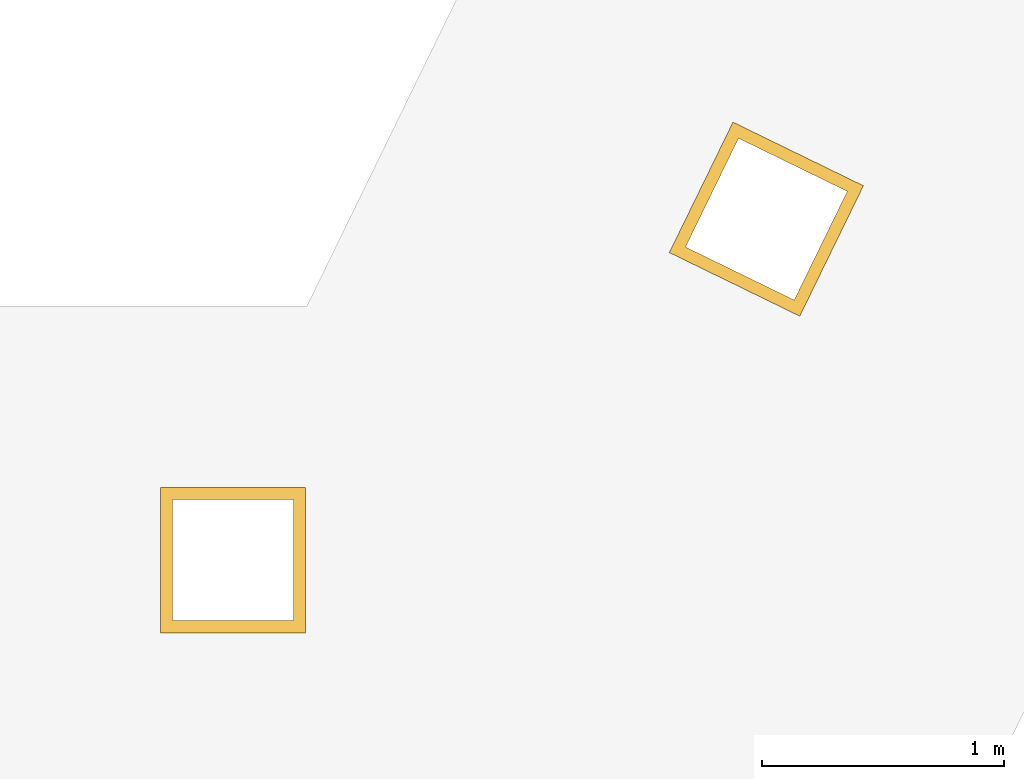
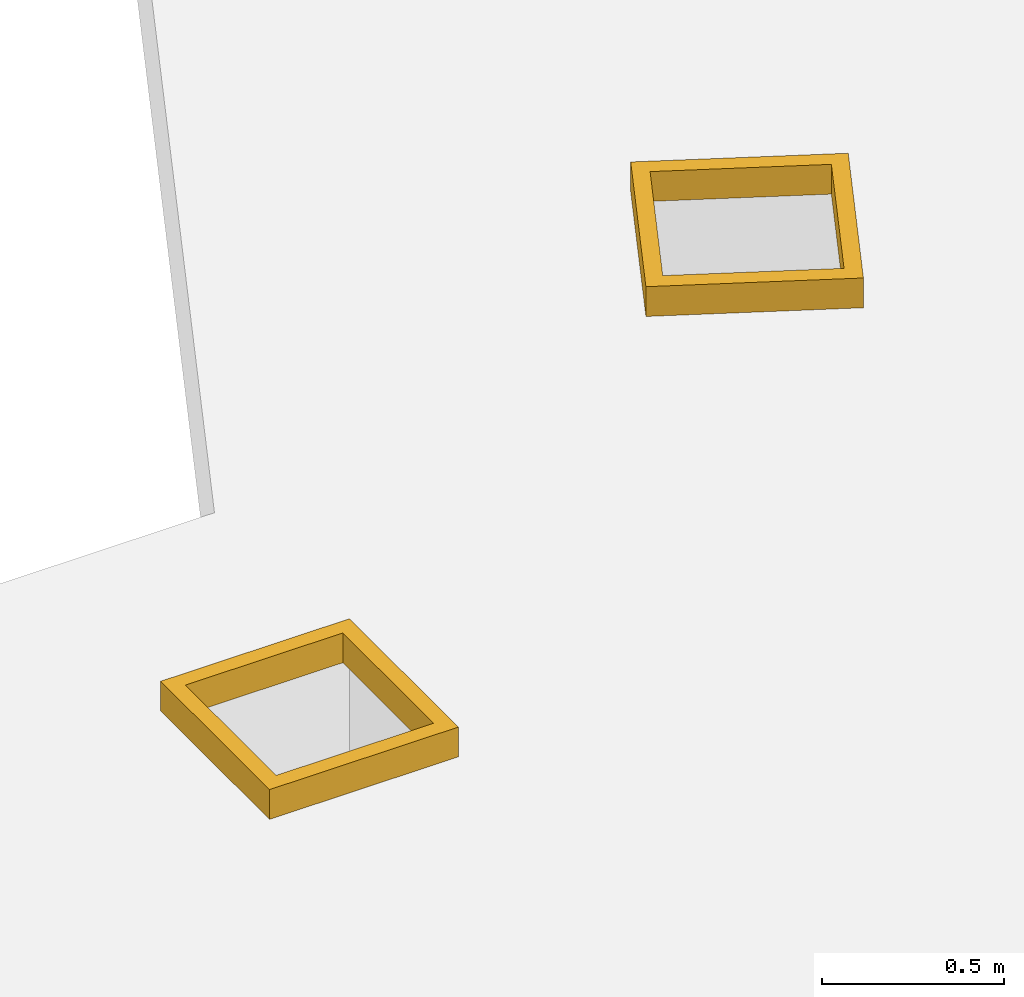
# One storey, part 2 of 2: 2 windows.
"""IFC4 building model written with IfcOpenShell, lengths in metres."""

import ifcopenshell
import ifcopenshell.guid

model = None  # the IFC model being written
_history = None  # IfcOwnerHistory: only IFC2X3 demands one
_inside = {}  # id of a spatial element -> (the spatial element, [elements in it])
_under = {}  # id of a project, library or spatial element -> (it, [spatial elements below it])
_declared = {}  # id of a project -> (the project, [libraries it declares])
_typed = {}  # id of a type object -> (the type object, [elements of that type])
_made_of = {}  # id of a material, layer set ... -> (it, [elements and type objects made of it])


def new_model(schema):
    """Start an empty IFC model of exactly this schema.

    Asked for "IFC4X3", IfcOpenShell would pick the latest addendum, in which some entities
    have other attributes; the version numbers below select the first issue.
    IFC2X3 requires an IfcOwnerHistory on every rooted entity: one is made here for all.
    """
    global model, _history
    if schema == "IFC4X3":
        model = ifcopenshell.file(schema_version=(4, 3, 0, 0))
    else:
        model = ifcopenshell.file(schema=schema)
    _inside.clear()
    _under.clear()
    _declared.clear()
    _typed.clear()
    _made_of.clear()
    _history = None
    if model.schema == "IFC2X3":
        org = make("IfcOrganization", Name="unknown")
        user = make(
            "IfcPersonAndOrganization",
            ThePerson=make("IfcPerson", FamilyName="unknown"),
            TheOrganization=org,
        )
        app = make(
            "IfcApplication",
            ApplicationDeveloper=org,
            Version="unknown",
            ApplicationFullName="unknown",
            ApplicationIdentifier="unknown",
        )
        _history = make(
            "IfcOwnerHistory",
            OwningUser=user,
            OwningApplication=app,
            ChangeAction="ADDED",
            CreationDate=0,
        )
    return model


def make(cls, **values):
    """One entity of the class cls with the attributes given. An attribute that is None is left unset."""
    return model.create_entity(
        cls, **{name: value for name, value in values.items() if value is not None}
    )


def entity(cls, *values):
    """Any entity or typed value of the class cls, its attributes in the order of the schema. None: left unset."""
    e = model.create_entity(cls)
    for i, value in enumerate(values):
        if value is not None:
            e[i] = value
    return e


def rooted(cls, **values):
    """An entity with a GlobalId (a new one), such as an element, a storey or a relation."""
    return make(cls, GlobalId=ifcopenshell.guid.new(), OwnerHistory=_history, **values)


def si_unit(unit_type, name, prefix=None):
    """IfcSIUnit, for example si_unit("LENGTHUNIT", "METRE", prefix="MILLI")."""
    return make("IfcSIUnit", UnitType=unit_type, Prefix=prefix, Name=name)


def converted_unit(unit_type, name, factor, base, dimensions=None, offset=None):
    """IfcConversionBasedUnit, such as the inch: factor (a typed value) times the base unit."""
    return make(
        "IfcConversionBasedUnit"
        if offset is None
        else "IfcConversionBasedUnitWithOffset",
        ConversionOffset=offset,
        Dimensions=None
        if dimensions is None
        else entity("IfcDimensionalExponents", *dimensions),
        UnitType=unit_type,
        Name=name,
        ConversionFactor=make(
            "IfcMeasureWithUnit", ValueComponent=factor, UnitComponent=base
        ),
    )


def derived_unit(unit_type, elements):
    """IfcDerivedUnit: a product of units, each with its exponent."""
    return make(
        "IfcDerivedUnit",
        Elements=[
            make("IfcDerivedUnitElement", Unit=unit, Exponent=power)
            for unit, power in elements
        ],
        UnitType=unit_type,
    )


def assignment(units):
    """IfcUnitAssignment: the units of a project."""
    return None if units is None else make("IfcUnitAssignment", Units=units)


def point(xyz):
    """IfcCartesianPoint."""
    return None if xyz is None else make("IfcCartesianPoint", Coordinates=xyz)


def direction(xyz):
    """IfcDirection."""
    return None if xyz is None else make("IfcDirection", DirectionRatios=xyz)


def frame(location, z_axis=None, x_axis=None):
    """IfcAxis2Placement3D, a coordinate frame: its origin and axes. An axis left out is left unset."""
    return make(
        "IfcAxis2Placement3D",
        Location=point(location),
        Axis=direction(z_axis),
        RefDirection=direction(x_axis),
    )


def origin():
    """The frame at (0, 0, 0) with its axes left unset."""
    return frame((0.0, 0.0, 0.0))


def place(relative_to, where):
    """IfcLocalPlacement: puts the frame where relative to a parent placement (None: the world)."""
    return make(
        "IfcLocalPlacement", PlacementRelTo=relative_to, RelativePlacement=where
    )


def context(
    kind, dimensions, precision=None, world=None, true_north=None, identifier=None
):
    """IfcGeometricRepresentationContext, for example the 3D "Model" context."""
    return make(
        "IfcGeometricRepresentationContext",
        ContextIdentifier=identifier,
        ContextType=kind,
        CoordinateSpaceDimension=dimensions,
        Precision=precision,
        WorldCoordinateSystem=world,
        TrueNorth=true_north,
    )


def subcontext(parent, identifier, kind, view, scale=None):
    """IfcGeometricRepresentationSubContext, for example "Body" below "Model"."""
    return make(
        "IfcGeometricRepresentationSubContext",
        ContextIdentifier=identifier,
        ContextType=kind,
        ParentContext=parent,
        TargetScale=scale,
        TargetView=view,
    )


def project(units=None, contexts=None):
    """IfcProject with its units and contexts."""
    return rooted(
        "IfcProject",
        Name="project",
        RepresentationContexts=contexts,
        UnitsInContext=assignment(units),
    )


def spatial(cls, under=None, at=None, **own):
    """A site, building, storey or space (cls), placed at a placement, below another one or the project."""
    s = rooted(cls, ObjectPlacement=at, **own)
    if under is not None:
        _under.setdefault(under.id(), (under, []))[1].append(s)
    return s


def point_list(points):
    """IfcCartesianPointList2D or 3D."""
    cls = (
        "IfcCartesianPointList2D" if len(points[0]) == 2 else "IfcCartesianPointList3D"
    )
    return make(cls, CoordList=points)


def polygons(points, faces, closed=None, point_numbers=None):
    """IfcPolygonalFaceSet: a face is its outer loop, then its inner loops; points numbered from 1."""
    made = []
    for loops in faces:
        if len(loops) == 1:
            made.append(make("IfcIndexedPolygonalFace", CoordIndex=loops[0]))
        else:
            made.append(
                make(
                    "IfcIndexedPolygonalFaceWithVoids",
                    CoordIndex=loops[0],
                    InnerCoordIndices=loops[1:],
                )
            )
    return make(
        "IfcPolygonalFaceSet",
        Coordinates=point_list(points),
        Closed=closed,
        Faces=made,
        PnIndex=point_numbers,
    )


def shape(context_of_items, identifier, shape_type, items):
    """IfcShapeRepresentation: the items that make up one representation, for example the "Body"."""
    return make(
        "IfcShapeRepresentation",
        ContextOfItems=context_of_items,
        RepresentationIdentifier=identifier,
        RepresentationType=shape_type,
        Items=items,
    )


def source(mapping_origin, context_of_items, identifier, shape_type, items):
    """IfcRepresentationMap: a shape defined once, which mapped items show again and again."""
    return make(
        "IfcRepresentationMap",
        MappingOrigin=mapping_origin,
        MappedRepresentation=shape(context_of_items, identifier, shape_type, items),
    )


def transform(
    local_origin,
    x_axis=None,
    y_axis=None,
    z_axis=None,
    scale=None,
    scale2=None,
    scale3=None,
    uniform=True,
):
    """IfcCartesianTransformationOperator3D, or its non-uniform kind. x_axis, y_axis, z_axis: its Axis1, 2, 3."""
    if uniform:
        return make(
            "IfcCartesianTransformationOperator3D",
            Axis1=direction(x_axis),
            Axis2=direction(y_axis),
            LocalOrigin=point(local_origin),
            Scale=scale,
            Axis3=direction(z_axis),
        )
    return make(
        "IfcCartesianTransformationOperator3DnonUniform",
        Axis1=direction(x_axis),
        Axis2=direction(y_axis),
        LocalOrigin=point(local_origin),
        Scale=scale,
        Axis3=direction(z_axis),
        Scale2=scale2,
        Scale3=scale3,
    )


def mapped(mapping_source, mapping_target):
    """IfcMappedItem: shows the shape of a source again, moved by a transform."""
    return make(
        "IfcMappedItem", MappingSource=mapping_source, MappingTarget=mapping_target
    )


def material(Name=None, Category=None):
    """IfcMaterial."""
    return make("IfcMaterial", Name=Name, Category=Category)


def made_of(thing, what):
    """Note that an element or type object is made of a material, layer set ...; save() writes the relation."""
    if what is not None:
        _made_of.setdefault(what.id(), (what, []))[1].append(thing)
    return thing


def type_object(cls, material=None, **own):
    """A type object (cls), such as IfcWallType, which elements share."""
    return made_of(rooted(cls, **own), material)


def type_shapes(of_type, sources):
    """Give a type object the sources (RepresentationMaps) that its elements show as mapped items."""
    of_type.RepresentationMaps = sources


def element(
    cls,
    number,
    at=None,
    inside=None,
    cuts=None,
    type_object=None,
    material=None,
    context=None,
    identifier="Body",
    shape_type=None,
    held_by="IfcProductDefinitionShape",
    body=None,
    shapes=None,
    **own,
):
    """One element of the class cls, such as IfcWall. Its Tag is "e" and its number.

    at: its placement. inside: the storey or other place that contains it. cuts: it is an
    opening in that element (IfcRelVoidsElement). A single representation is given by context,
    identifier, shape_type and body (its items); several are given by shapes. held_by: the class
    of the entity that holds the representations. save() writes the other relations.
    """
    e = rooted(cls, Tag="e%d" % number, ObjectPlacement=at, **own)
    if body is not None:
        shapes = [shape(context, identifier, shape_type, body)]
    if shapes is not None:
        e.Representation = make(held_by, Representations=shapes)
    if inside is not None:
        _inside.setdefault(inside.id(), (inside, []))[1].append(e)
    if cuts is not None:
        rooted(
            "IfcRelVoidsElement", RelatingBuildingElement=cuts, RelatedOpeningElement=e
        )
    if type_object is not None:
        _typed.setdefault(type_object.id(), (type_object, []))[1].append(e)
    return made_of(e, material)


def aggregate(whole, parts):
    """IfcRelAggregates: a whole, such as a stair, and the parts it consists of."""
    return rooted("IfcRelAggregates", RelatingObject=whole, RelatedObjects=parts)


def save(model, path):
    """Write the relations noted so far, then the file.

    IfcRelAggregates (storeys below a building ...), IfcRelContainedInSpatialStructure (elements
    in a storey), IfcRelDefinesByType, IfcRelAssociatesMaterial and IfcRelDeclares: one each for
    every whole, place, type object, material and project.
    """
    for whole, parts in _under.values():
        aggregate(whole, parts)
    for where, things in _inside.values():
        rooted(
            "IfcRelContainedInSpatialStructure",
            RelatedElements=things,
            RelatingStructure=where,
        )
    for kind, things in _typed.values():
        rooted("IfcRelDefinesByType", RelatedObjects=things, RelatingType=kind)
    for what, things in _made_of.values():
        rooted("IfcRelAssociatesMaterial", RelatedObjects=things, RelatingMaterial=what)
    for by, libraries in _declared.values():
        rooted("IfcRelDeclares", RelatingContext=by, RelatedDefinitions=libraries)
    model.write(path)


model = new_model("IFC4")

# Units and contexts
model_context = context("Model", 3, precision=1e-05, world=origin(), true_north=direction((6.12303176911189e-17, 1.0)))
body_context = subcontext(model_context, "Body", "Model", "MODEL_VIEW")
ifc_project = project(units=[si_unit("LENGTHUNIT", "METRE"), si_unit("AREAUNIT", "SQUARE_METRE"), si_unit("VOLUMEUNIT", "CUBIC_METRE"), converted_unit("PLANEANGLEUNIT", "DEGREE", entity("IfcRatioMeasure", 0.0174532925199433), si_unit("PLANEANGLEUNIT", "RADIAN"), dimensions=[0, 0, 0, 0, 0, 0, 0]), si_unit("MASSUNIT", "GRAM", prefix="KILO"), derived_unit("MASSDENSITYUNIT", [(si_unit("MASSUNIT", "GRAM", prefix="KILO"), 1), (si_unit("LENGTHUNIT", "METRE"), -3)]), si_unit("TIMEUNIT", "SECOND"), si_unit("FREQUENCYUNIT", "HERTZ"), si_unit("THERMODYNAMICTEMPERATUREUNIT", "DEGREE_CELSIUS"), derived_unit("THERMALTRANSMITTANCEUNIT", [(si_unit("MASSUNIT", "GRAM", prefix="KILO"), 1), (si_unit("THERMODYNAMICTEMPERATUREUNIT", "KELVIN"), -1), (si_unit("TIMEUNIT", "SECOND"), -3)]), derived_unit("VOLUMETRICFLOWRATEUNIT", [(si_unit("LENGTHUNIT", "METRE"), 3), (si_unit("TIMEUNIT", "SECOND"), -1)]), si_unit("ELECTRICCURRENTUNIT", "AMPERE"), si_unit("ELECTRICVOLTAGEUNIT", "VOLT"), si_unit("POWERUNIT", "WATT"), si_unit("FORCEUNIT", "NEWTON", prefix="KILO"), si_unit("ILLUMINANCEUNIT", "LUX"), si_unit("LUMINOUSFLUXUNIT", "LUMEN"), si_unit("LUMINOUSINTENSITYUNIT", "CANDELA"), derived_unit("USERDEFINED", [(si_unit("MASSUNIT", "GRAM", prefix="KILO"), -1), (si_unit("LENGTHUNIT", "METRE"), -2), (si_unit("TIMEUNIT", "SECOND"), 3), (si_unit("LUMINOUSFLUXUNIT", "LUMEN"), 1)]), derived_unit("LINEARVELOCITYUNIT", [(si_unit("LENGTHUNIT", "METRE"), 1), (si_unit("TIMEUNIT", "SECOND"), -1)]), si_unit("PRESSUREUNIT", "PASCAL"), derived_unit("USERDEFINED", [(si_unit("LENGTHUNIT", "METRE"), -2), (si_unit("MASSUNIT", "GRAM", prefix="KILO"), 1), (si_unit("TIMEUNIT", "SECOND"), -2)])], contexts=[model_context])

# Site, building, storey
site_placement = place(None, origin())
site = spatial("IfcSite", under=ifc_project, at=site_placement, CompositionType="ELEMENT")
building_placement = place(site_placement, origin())
building = spatial("IfcBuilding", under=site, at=building_placement, Name="Revit Advanced Sample", CompositionType="ELEMENT")
storey_placement = place(building_placement, frame((0.0, 0.0, 3.80000000000133)))
storey = spatial("IfcBuildingStorey", under=building, at=storey_placement, Name="E1", CompositionType="ELEMENT", Elevation=3.80000000000133)

# Windows
ifc_material = material()
window_type = type_object("IfcWindowType", Name="600mm x 600mm", ParameterTakesPrecedence=False, PartitioningType="NOTDEFINED", PredefinedType="WINDOW", material=ifc_material)
shared_shape = source(origin(), body_context, "Body", "Tessellation", [
    polygons([(-0.380000000000003, -0.560000000000002, 4.0576), (-0.330000000000012, -0.510000000000011, 4.0576), (0.170000000000005, -0.510000000000011, 4.0576), (0.219999999999996, -0.560000000000002, 4.0576), (-0.380000000000003, -0.560000000000002, 4.1576), (0.219999999999996, -0.560000000000002, 4.1576), (-0.330000000000012, -0.510000000000011, 4.1576), (0.170000000000005, -0.510000000000011, 4.1576), (0.170000000000005, -0.00999999999999482, 4.0576), (0.219999999999996, 0.039999999999996, 4.0576), (0.219999999999996, 0.039999999999996, 4.1576), (0.170000000000005, -0.00999999999999482, 4.1576), (-0.330000000000012, -0.00999999999999483, 4.0576), (-0.380000000000003, 0.0399999999999959, 4.0576), (-0.380000000000003, 0.0399999999999959, 4.1576), (-0.330000000000012, -0.00999999999999483, 4.1576)], [[[1, 14, 10, 4], [3, 9, 13, 2]], [[5, 1, 4, 6]], [[9, 12, 16, 13]], [[6, 11, 15, 5], [7, 16, 12, 8]], [[2, 7, 8, 3]], [[11, 10, 14, 15]], [[6, 4, 10, 11]], [[13, 16, 7, 2]], [[3, 8, 12, 9]], [[15, 14, 1, 5]]], closed=True),
])
type_shapes(window_type, [shared_shape])
window_1_placement = place(storey_placement, frame((0.781761701821966, -3.43603282121672, -3.6576)))
element("IfcWindow", 1, at=window_1_placement, inside=storey, type_object=window_type, material=ifc_material, OverallHeight=0.778250561573641, OverallWidth=0.997150419015361, PartitioningType="NOTDEFINED", PredefinedType="WINDOW", context=body_context, shape_type="MappedRepresentation", body=[
    mapped(shared_shape, transform((0.0, 0.0, 0.0), scale=1.0)),
])
window_2_placement = place(storey_placement, frame((3.09185339799384, -2.08771523470036, -3.6576), z_axis=(0.0, 0.0, 1.0), x_axis=(0.898794046299166, -0.438371146789079, 0.0)))
element("IfcWindow", 2, at=window_2_placement, inside=storey, type_object=window_type, material=ifc_material, OverallHeight=0.778250561573641, OverallWidth=0.997150419015361, PartitioningType="NOTDEFINED", PredefinedType="WINDOW", context=body_context, shape_type="MappedRepresentation", body=[
    mapped(shared_shape, transform((0.0, 0.0, 0.0), scale=1.0)),
])

save(model, "model.ifc")
